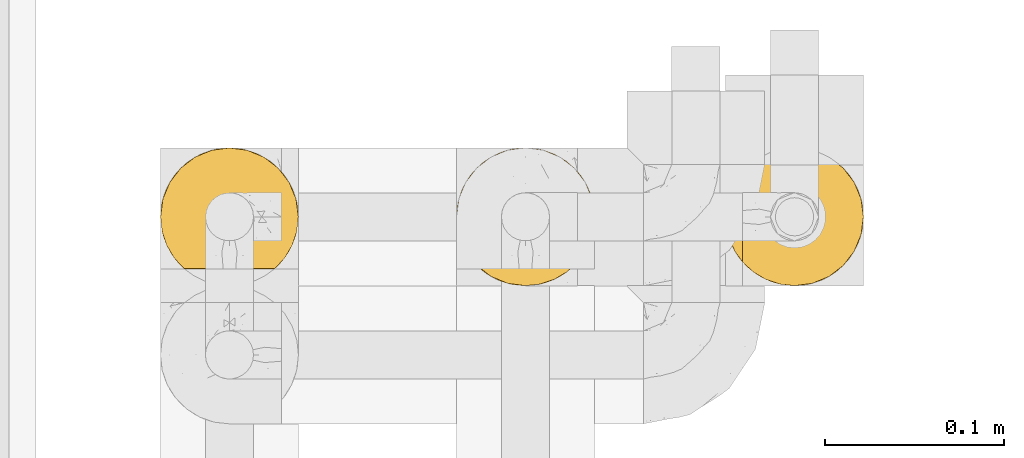
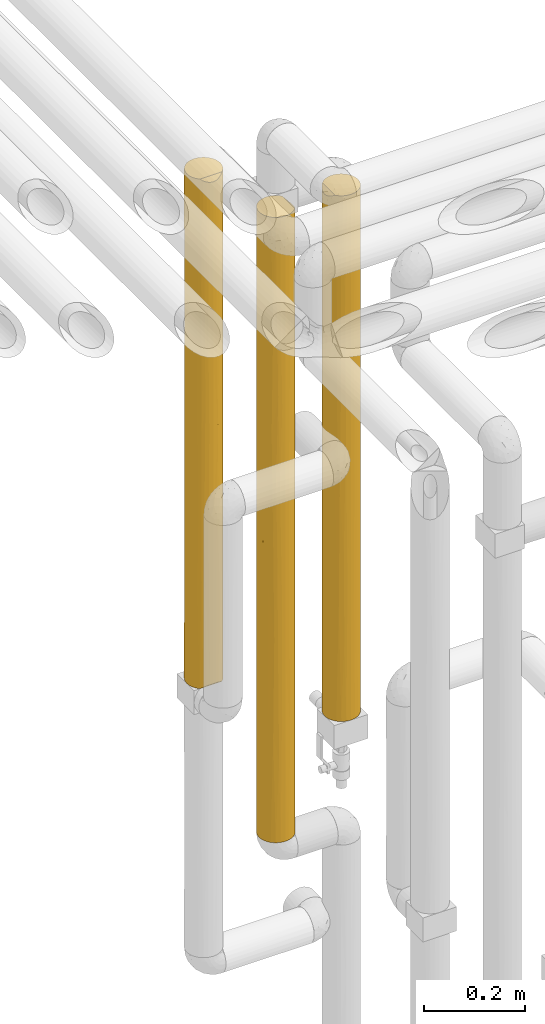
# One storey, part 40 of 827: 3 coverings.
"""IFC2X3 building model written with IfcOpenShell, lengths in millimetres."""

from ifc_helpers import new_model, entity, si_unit, converted_unit, derived_unit, direction, frame, origin, place, context, subcontext, project, spatial, faceted_brep, element, save


model = new_model("IFC2X3")

# Units and contexts
model_context = context("Model", 3, precision=0.01, world=origin(), true_north=direction((6.12303176911189e-17, 1.0)))
body_context = subcontext(model_context, "Body", "Model", "MODEL_VIEW")
ifc_project = project(units=[si_unit("LENGTHUNIT", "METRE", prefix="MILLI"), si_unit("AREAUNIT", "SQUARE_METRE"), si_unit("VOLUMEUNIT", "CUBIC_METRE"), converted_unit("PLANEANGLEUNIT", "DEGREE", entity("IfcRatioMeasure", 0.0174532925199433), si_unit("PLANEANGLEUNIT", "RADIAN"), dimensions=[0, 0, 0, 0, 0, 0, 0]), si_unit("MASSUNIT", "GRAM", prefix="KILO"), derived_unit("MASSDENSITYUNIT", [(si_unit("MASSUNIT", "GRAM", prefix="KILO"), 1), (si_unit("LENGTHUNIT", "METRE"), -3)]), derived_unit("MOMENTOFINERTIAUNIT", [(si_unit("LENGTHUNIT", "METRE"), 4)]), si_unit("TIMEUNIT", "SECOND"), si_unit("FREQUENCYUNIT", "HERTZ"), si_unit("THERMODYNAMICTEMPERATUREUNIT", "DEGREE_CELSIUS"), derived_unit("THERMALTRANSMITTANCEUNIT", [(si_unit("MASSUNIT", "GRAM", prefix="KILO"), 1), (si_unit("THERMODYNAMICTEMPERATUREUNIT", "KELVIN"), -1), (si_unit("TIMEUNIT", "SECOND"), -3)]), derived_unit("VOLUMETRICFLOWRATEUNIT", [(si_unit("LENGTHUNIT", "METRE"), 3), (si_unit("TIMEUNIT", "SECOND"), -1)]), derived_unit("MASSFLOWRATEUNIT", [(si_unit("MASSUNIT", "GRAM", prefix="KILO"), 1), (si_unit("TIMEUNIT", "SECOND"), -1)]), derived_unit("ROTATIONALFREQUENCYUNIT", [(si_unit("TIMEUNIT", "SECOND"), -1)]), si_unit("ELECTRICCURRENTUNIT", "AMPERE"), si_unit("ELECTRICVOLTAGEUNIT", "VOLT"), si_unit("POWERUNIT", "WATT"), si_unit("FORCEUNIT", "NEWTON", prefix="KILO"), si_unit("ILLUMINANCEUNIT", "LUX"), si_unit("LUMINOUSFLUXUNIT", "LUMEN"), si_unit("LUMINOUSINTENSITYUNIT", "CANDELA"), derived_unit("USERDEFINED", [(si_unit("MASSUNIT", "GRAM", prefix="KILO"), -1), (si_unit("LENGTHUNIT", "METRE"), -2), (si_unit("TIMEUNIT", "SECOND"), 3), (si_unit("LUMINOUSFLUXUNIT", "LUMEN"), 1)]), derived_unit("LINEARVELOCITYUNIT", [(si_unit("LENGTHUNIT", "METRE"), 1), (si_unit("TIMEUNIT", "SECOND"), -1)]), si_unit("PRESSUREUNIT", "PASCAL"), derived_unit("USERDEFINED", [(si_unit("LENGTHUNIT", "METRE"), -2), (si_unit("MASSUNIT", "GRAM", prefix="KILO"), 1), (si_unit("TIMEUNIT", "SECOND"), -2)]), derived_unit("LINEARFORCEUNIT", [(si_unit("MASSUNIT", "GRAM", prefix="KILO"), 1), (si_unit("LENGTHUNIT", "METRE"), 1), (si_unit("TIMEUNIT", "SECOND"), -2), (si_unit("LENGTHUNIT", "METRE"), -1)]), derived_unit("PLANARFORCEUNIT", [(si_unit("MASSUNIT", "GRAM", prefix="KILO"), 1), (si_unit("LENGTHUNIT", "METRE"), 1), (si_unit("TIMEUNIT", "SECOND"), -2), (si_unit("LENGTHUNIT", "METRE"), -2)])], contexts=[model_context])

# Site, building, storey
site_placement = place(None, origin())
site = spatial("IfcSite", under=ifc_project, at=site_placement, CompositionType="ELEMENT")
building_placement = place(site_placement, origin())
building = spatial("IfcBuilding", under=site, at=building_placement, CompositionType="ELEMENT")
storey_placement = place(building_placement, frame((0.0, 0.0, 28200.0)))
storey = spatial("IfcBuildingStorey", under=building, at=storey_placement, Name="08", CompositionType="ELEMENT", Elevation=28200.0)

# Coverings
covering_1_placement = place(storey_placement, frame((34787.85, 15782.05, 1737.4)))
element("IfcCovering", 1, at=covering_1_placement, inside=storey, Name=":ADSK_", ObjectType=":ADSK_", PredefinedType="INSULATION", context=body_context, shape_type="Brep", body=[
    faceted_brep([(70.82, 17.09, 1233.7), (74.96, 24.12, 1233.7), (77.53, 31.87, 1233.7), (78.4, 40.0, 1233.7), (77.09, 49.93, 1233.7), (73.25, 59.2, 1233.7), (67.15, 67.15, 1233.7), (59.2, 73.25, 1233.7), (49.93, 77.09, 1233.7), (40.0, 78.4, 1233.7), (30.06, 77.09, 1233.7), (20.8, 73.25, 1233.7), (12.84, 67.15, 1233.7), (6.74, 59.2, 1233.7), (2.9, 49.93, 1233.7), (1.6, 40.0, 1233.7), (2.47, 31.87, 1233.7), (5.03, 24.12, 1233.7), (9.17, 17.09, 1233.7), (14.71, 11.1, 1233.7), (65.28, 11.1, 1233.7), (77.09, 49.93, 1.6), (78.4, 40.0, 1.6), (77.52, 31.83, 1.6), (74.93, 24.05, 1.6), (70.75, 17.0, 1.6), (65.17, 11.0, 1.6), (14.82, 11.0, 1.6), (9.24, 17.0, 1.6), (5.06, 24.05, 1.6), (2.47, 31.83, 1.6), (1.6, 40.0, 1.6), (2.9, 49.93, 1.6), (6.74, 59.2, 1.6), (12.84, 67.15, 1.6), (20.8, 73.25, 1.6), (30.06, 77.09, 1.6), (40.0, 78.4, 1.6), (49.93, 77.09, 1.6), (59.2, 73.25, 1.6), (67.15, 67.15, 1.6), (73.25, 59.2, 1.6), (6.96, 20.41, 380.1), (2.98, 29.79, 300.66), (33.13, 2.21, 1224.81), (26.49, 4.05, 1226.65), (29.66, 3.01, 854.96), (1.6, 40.0, 1017.32), (3.54, 27.93, 959.65), (29.71, 3.0, 379.5), (40.0, 1.6, 314.3), (31.58, 2.53, 617.43), (6.92, 20.49, 1020.27), (6.91, 20.5, 776.67), (2.89, 30.11, 632.09), (17.23, 9.07, 932.57), (11.14, 14.65, 898.16), (11.15, 14.65, 658.7), (1.6, 40.0, 368.2), (1.6, 40.0, 217.97), (20.38, 6.98, 5.61), (26.56, 4.02, 8.57), (23.95, 5.11, 227.33), (7.37, 19.74, 578.55), (17.34, 8.99, 302.5), (11.15, 14.64, 236.7), (22.57, 5.78, 457.71), (33.17, 2.21, 10.38), (40.0, 1.6, 920.9), (24.03, 5.07, 687.57), (20.28, 7.04, 1229.64), (23.14, 5.49, 889.56), (17.16, 9.12, 617.33), (40.0, 1.6, 1007.82), (40.0, 1.6, 1224.2), (40.0, 1.6, 443.74), (40.0, 1.6, 617.6), (40.0, 1.6, 791.45), (1.6, 40.0, 800.95), (1.6, 40.0, 650.72), (1.6, 40.0, 584.58), (1.6, 40.0, 434.34), (12.88, 12.81, 447.73), (40.0, 1.6, 11.0), (40.0, 1.6, 227.37), (1.6, 40.0, 867.09), (46.86, 2.21, 1224.81), (78.4, 40.0, 368.2), (77.01, 29.79, 300.8), (62.94, 9.2, 617.95), (56.74, 5.44, 340.29), (65.84, 11.59, 318.76), (62.5, 8.88, 1022.28), (64.23, 10.21, 822.23), (68.21, 13.95, 960.82), (56.83, 5.48, 896.27), (59.71, 7.04, 1229.64), (53.5, 4.05, 1226.65), (59.61, 6.98, 5.61), (78.4, 40.0, 1017.32), (73.03, 20.41, 381.62), (46.82, 2.21, 10.38), (53.43, 4.02, 8.57), (48.19, 2.48, 335.55), (48.24, 2.49, 899.64), (73.08, 20.5, 1021.95), (76.45, 27.93, 960.83), (77.09, 30.08, 632.84), (73.08, 20.5, 779.63), (52.39, 3.65, 617.28), (74.53, 23.2, 580.01), (69.54, 15.47, 581.84), (78.4, 40.0, 800.95), (78.4, 40.0, 584.58), (70.46, 63.37, 260.79), (63.37, 70.46, 325.87), (77.74, 47.07, 909.14), (77.52, 48.15, 600.24), (75.47, 54.69, 874.58), (75.47, 54.69, 360.71), (77.67, 47.41, 240.44), (40.0, 78.4, 217.97), (74.83, 56.16, 600.23), (47.38, 77.68, 930.39), (54.69, 75.47, 246.65), (62.73, 70.94, 600.23), (54.69, 75.47, 531.31), (47.28, 77.7, 326.15), (63.37, 70.46, 874.58), (54.69, 75.47, 966.5), (70.46, 63.37, 966.5), (51.75, 76.55, 748.91), (70.46, 63.37, 617.65), (46.88, 77.77, 563.24), (40.0, 78.4, 368.2), (40.0, 78.4, 434.34), (40.0, 78.4, 650.71), (40.0, 78.4, 800.95), (40.0, 78.4, 867.08), (40.0, 78.4, 1017.32), (40.0, 78.4, 584.57), (16.62, 70.46, 260.79), (9.53, 63.37, 325.87), (32.92, 77.74, 909.14), (31.84, 77.52, 600.24), (25.3, 75.47, 874.58), (25.3, 75.47, 360.71), (32.58, 77.67, 240.44), (23.83, 74.83, 600.23), (2.31, 47.38, 930.39), (4.52, 54.69, 246.65), (9.05, 62.73, 600.23), (4.52, 54.69, 531.31), (2.29, 47.28, 326.15), (9.53, 63.37, 874.58), (4.52, 54.69, 966.5), (16.62, 70.46, 966.5), (3.44, 51.75, 748.91), (16.62, 70.46, 617.65), (2.22, 46.88, 563.24)], [[[0, 1, 2, 3, 4, 5, 6, 7, 8, 9, 10, 11, 12, 13, 14, 15, 16, 17, 18, 19, 20]], [[21, 22, 23, 24, 25, 26, 27, 28, 29, 30, 31, 32, 33, 34, 35, 36, 37, 38, 39, 40, 41]], [[42, 43, 29]], [[44, 45, 46]], [[16, 47, 48]], [[48, 17, 16]], [[49, 50, 51]], [[52, 48, 53]], [[53, 48, 54]], [[30, 43, 31]], [[55, 56, 57]], [[43, 58, 59, 31]], [[60, 61, 62]], [[63, 54, 42]], [[48, 52, 17]], [[27, 64, 65]], [[28, 65, 42]], [[62, 49, 66]], [[67, 62, 61]], [[29, 28, 42]], [[44, 46, 68]], [[56, 18, 52]], [[66, 51, 69]], [[67, 50, 49]], [[62, 67, 49]], [[45, 70, 71]], [[72, 55, 57]], [[44, 68, 73, 74]], [[19, 18, 56]], [[70, 19, 55]], [[51, 50, 75, 76, 77, 68]], [[71, 70, 55]], [[72, 69, 71]], [[60, 64, 27]], [[54, 78, 79, 80, 81, 58]], [[72, 57, 82]], [[54, 48, 78]], [[58, 43, 54]], [[56, 52, 53]], [[17, 52, 18]], [[56, 53, 57]], [[56, 55, 19]], [[53, 63, 57]], [[42, 65, 82]], [[54, 63, 53]], [[82, 63, 42]], [[51, 68, 46]], [[67, 83, 84, 50]], [[69, 51, 46]], [[71, 69, 46]], [[72, 64, 66]], [[45, 71, 46]], [[72, 71, 55]], [[29, 43, 30]], [[54, 43, 42]], [[49, 51, 66]], [[60, 62, 64]], [[72, 66, 69]], [[64, 62, 66]], [[27, 65, 28]], [[82, 65, 64]], [[72, 82, 64]], [[82, 57, 63]], [[47, 16, 15]], [[48, 47, 85, 78]], [[86, 74, 73]], [[87, 88, 22]], [[89, 90, 91]], [[92, 93, 94]], [[95, 96, 97]], [[98, 91, 90]], [[91, 98, 26]], [[99, 3, 2]], [[91, 25, 100]], [[101, 102, 103]], [[20, 94, 0]], [[102, 98, 90]], [[104, 73, 68, 77]], [[1, 105, 106]], [[73, 104, 86]], [[107, 106, 108]], [[103, 109, 75]], [[20, 96, 92]], [[88, 23, 22]], [[24, 23, 88]], [[100, 110, 111]], [[0, 105, 1]], [[1, 106, 2]], [[92, 96, 95]], [[106, 107, 112]], [[88, 107, 110]], [[97, 86, 104]], [[84, 83, 101]], [[2, 106, 99]], [[89, 95, 109]], [[103, 90, 109]], [[108, 105, 94]], [[94, 93, 111]], [[25, 24, 100]], [[103, 102, 90]], [[103, 75, 50, 84]], [[101, 103, 84]], [[95, 104, 109]], [[109, 77, 76, 75]], [[104, 95, 97]], [[109, 90, 89]], [[77, 109, 104]], [[110, 107, 108]], [[107, 87, 113, 112]], [[94, 105, 0]], [[106, 105, 108]], [[25, 91, 26]], [[111, 91, 100]], [[24, 88, 100]], [[94, 111, 108]], [[91, 111, 89]], [[93, 95, 89]], [[20, 92, 94]], [[95, 93, 92]], [[111, 93, 89]], [[106, 112, 99]], [[111, 110, 108]], [[88, 110, 100]], [[87, 107, 88]], [[114, 40, 115]], [[116, 117, 118]], [[4, 99, 116]], [[4, 118, 5]], [[21, 41, 119]], [[120, 22, 21]], [[38, 37, 121]], [[87, 120, 117]], [[118, 117, 122]], [[9, 8, 123]], [[39, 124, 115]], [[125, 115, 126]], [[124, 127, 126]], [[120, 21, 119]], [[112, 116, 99]], [[128, 129, 7]], [[130, 6, 5]], [[39, 38, 124]], [[39, 115, 40]], [[118, 130, 5]], [[128, 7, 6]], [[123, 129, 131]], [[128, 130, 132]], [[132, 114, 115]], [[125, 132, 115]], [[7, 129, 8]], [[40, 114, 41]], [[126, 127, 133]], [[114, 132, 119]], [[132, 130, 118]], [[131, 128, 125]], [[131, 126, 133]], [[128, 6, 130]], [[119, 41, 114]], [[121, 127, 38]], [[115, 124, 126]], [[127, 121, 134, 135]], [[127, 135, 133]], [[38, 127, 124]], [[123, 136, 137, 138, 139, 9]], [[133, 136, 131]], [[4, 3, 99]], [[128, 131, 129]], [[8, 129, 123]], [[136, 123, 131]], [[133, 135, 140, 136]], [[117, 116, 112]], [[4, 116, 118]], [[117, 112, 113, 87]], [[117, 119, 122]], [[117, 120, 119]], [[22, 120, 87]], [[131, 125, 126]], [[132, 125, 128]], [[119, 132, 122]], [[118, 122, 132]], [[141, 34, 142]], [[143, 144, 145]], [[10, 139, 143]], [[10, 145, 11]], [[36, 35, 146]], [[147, 37, 36]], [[32, 31, 59]], [[134, 147, 144]], [[145, 144, 148]], [[15, 14, 149]], [[33, 150, 142]], [[151, 142, 152]], [[150, 153, 152]], [[147, 36, 146]], [[143, 139, 138, 137]], [[154, 155, 13]], [[156, 12, 11]], [[33, 32, 150]], [[33, 142, 34]], [[145, 156, 11]], [[154, 13, 12]], [[149, 155, 157]], [[154, 156, 158]], [[158, 141, 142]], [[151, 158, 142]], [[13, 155, 14]], [[34, 141, 35]], [[152, 153, 159]], [[141, 158, 146]], [[157, 154, 151]], [[157, 152, 159]], [[158, 156, 145]], [[154, 12, 156]], [[146, 35, 141]], [[59, 153, 32]], [[142, 150, 152]], [[153, 59, 58, 81]], [[153, 81, 159]], [[32, 153, 150]], [[149, 79, 78, 85, 47, 15]], [[159, 79, 157]], [[10, 9, 139]], [[154, 157, 155]], [[14, 155, 149]], [[79, 149, 157]], [[159, 81, 80, 79]], [[144, 143, 137]], [[10, 143, 145]], [[144, 137, 136, 140, 135, 134]], [[144, 146, 148]], [[144, 147, 146]], [[147, 134, 121, 37]], [[157, 151, 152]], [[158, 151, 154]], [[146, 158, 148]], [[145, 148, 158]], [[70, 45, 44, 74, 86, 97, 96, 20, 19]], [[98, 102, 101, 83, 67, 61, 60, 27, 26]]]),
])
covering_2_placement = place(storey_placement, frame((34952.89, 15782.05, 1307.5)))
element("IfcCovering", 2, at=covering_2_placement, inside=storey, Name=":ADSK_", ObjectType=":ADSK_", PredefinedType="INSULATION", context=body_context, shape_type="Brep", body=[
    faceted_brep([(6.74, 20.8, 1.6), (2.9, 30.06, 1.6), (1.6, 40.0, 1.6), (2.9, 49.93, 1.6), (6.74, 59.2, 1.6), (12.84, 67.15, 1.6), (20.8, 73.25, 1.6), (30.06, 77.09, 1.6), (40.0, 78.4, 1.6), (48.2, 77.51, 1.6), (56.01, 74.9, 1.6), (63.08, 70.68, 1.6), (69.1, 65.05, 1.6), (69.1, 14.94, 1.6), (63.08, 9.31, 1.6), (56.01, 5.09, 1.6), (48.2, 2.48, 1.6), (40.0, 1.6, 1.6), (30.06, 2.9, 1.6), (20.8, 6.74, 1.6), (12.84, 12.84, 1.6), (1.6, 40.0, 1513.5), (2.9, 30.06, 1513.5), (6.74, 20.8, 1513.5), (12.84, 12.84, 1513.5), (20.8, 6.74, 1513.5), (30.06, 2.9, 1513.5), (40.0, 1.6, 1513.5), (48.16, 2.47, 1513.5), (55.94, 5.06, 1513.5), (62.99, 9.24, 1513.5), (69.0, 14.82, 1513.5), (69.0, 65.17, 1513.5), (62.99, 70.75, 1513.5), (55.94, 74.93, 1513.5), (48.16, 77.52, 1513.5), (40.0, 78.4, 1513.5), (30.06, 77.09, 1513.5), (20.8, 73.25, 1513.5), (12.84, 67.15, 1513.5), (6.74, 59.2, 1513.5), (2.9, 49.93, 1513.5), (9.53, 63.37, 1254.3), (8.19, 61.51, 485.12), (17.02, 70.76, 616.68), (16.62, 70.46, 297.59), (16.62, 70.46, 1189.22), (2.34, 47.54, 1188.94), (4.37, 54.34, 1314.28), (4.52, 54.69, 1074.52), (25.3, 75.47, 204.96), (31.9, 77.53, 329.8), (2.32, 47.41, 921.21), (1.6, 40.0, 1080.75), (4.9, 55.59, 800.5), (1.6, 40.0, 324.8), (2.43, 47.94, 288.89), (40.0, 78.4, 324.8), (31.64, 77.48, 539.4), (33.12, 77.77, 951.85), (28.03, 76.48, 719.21), (25.3, 75.47, 983.78), (25.3, 75.47, 1268.44), (32.71, 77.7, 1188.94), (9.53, 63.37, 255.92), (4.52, 54.69, 175.66), (2.55, 48.52, 674.17), (25.3, 75.47, 454.64), (4.52, 54.69, 402.11), (17.9, 71.4, 946.7), (11.57, 65.81, 984.31), (40.0, 78.4, 1297.12), (1.6, 40.0, 1297.12), (1.6, 40.0, 648.0), (1.6, 40.0, 864.38), (9.53, 63.37, 714.31), (40.0, 78.4, 1080.75), (40.0, 78.4, 864.38), (40.0, 78.4, 648.0), (4.52, 54.69, 602.29), (40.0, 78.4, 217.97), (40.0, 78.4, 434.34), (48.41, 77.46, 864.38), (55.63, 75.07, 815.72), (49.96, 77.08, 541.17), (52.17, 76.41, 262.4), (59.58, 73.03, 1000.69), (52.12, 76.43, 1216.13), (59.58, 73.03, 1294.15), (59.71, 72.95, 245.23), (77.78, 46.82, 1504.71), (78.4, 40.0, 1287.72), (77.0, 50.24, 1261.84), (78.4, 40.0, 443.64), (78.4, 40.0, 227.27), (77.5, 48.24, 335.45), (76.0, 53.36, 8.5), (74.58, 56.68, 384.99), (74.53, 56.78, 1092.98), (73.77, 58.26, 1300.86), (75.97, 53.43, 1506.52), (66.14, 68.12, 1216.12), (67.04, 67.25, 938.77), (77.79, 46.78, 10.29), (70.57, 63.23, 410.64), (71.13, 62.48, 196.11), (66.24, 68.03, 287.24), (66.5, 67.78, 548.36), (78.4, 40.0, 1071.35), (77.38, 48.77, 973.87), (59.66, 72.98, 485.18), (78.4, 40.0, 876.39), (76.88, 50.68, 653.07), (78.4, 40.0, 660.02), (70.87, 62.83, 1155.43), (71.79, 61.52, 947.04), (73.07, 59.51, 5.57), (62.05, 71.43, 743.38), (75.0, 55.77, 846.38), (78.4, 40.0, 10.9), (73.01, 59.61, 1509.48), (74.34, 57.17, 650.34), (70.91, 62.77, 717.19), (78.4, 40.0, 1504.1), (52.17, 3.58, 262.4), (59.66, 7.01, 485.18), (49.96, 2.91, 541.17), (73.77, 21.73, 1300.86), (77.0, 29.75, 1261.84), (75.97, 26.56, 1506.52), (71.13, 17.51, 196.11), (74.58, 23.31, 384.99), (70.57, 16.76, 410.64), (40.0, 1.6, 434.34), (70.91, 17.22, 717.19), (62.05, 8.56, 743.38), (66.5, 12.21, 548.36), (52.12, 3.56, 1216.13), (59.58, 6.96, 1238.43), (70.87, 17.16, 1155.43), (66.14, 11.87, 1216.12), (77.78, 33.17, 1504.71), (67.04, 12.74, 938.77), (71.79, 18.47, 947.04), (76.0, 26.63, 8.5), (77.5, 31.75, 335.45), (77.79, 33.21, 10.29), (77.38, 31.23, 973.87), (55.63, 4.92, 815.72), (73.01, 20.38, 1509.48), (40.0, 1.6, 1297.12), (40.0, 1.6, 1190.29), (40.0, 1.6, 1080.75), (76.88, 29.31, 653.07), (59.58, 6.96, 1000.69), (59.75, 7.07, 217.41), (66.24, 11.96, 287.24), (48.41, 2.53, 864.38), (40.0, 1.6, 648.0), (40.0, 1.6, 867.09), (40.0, 1.6, 864.38), (40.0, 1.6, 650.71), (40.0, 1.6, 217.97), (75.0, 24.22, 846.38), (74.34, 22.82, 650.34), (74.53, 23.21, 1092.98), (73.07, 20.48, 5.57), (16.62, 9.53, 1254.3), (9.53, 16.62, 1189.22), (25.3, 4.52, 406.92), (32.71, 2.29, 326.15), (32.07, 2.42, 623.25), (25.3, 4.52, 1079.45), (22.93, 5.59, 1282.78), (28.78, 3.27, 853.31), (33.21, 2.2, 1053.48), (21.48, 6.35, 883.7), (23.82, 5.17, 655.64), (2.46, 31.9, 329.8), (2.52, 31.64, 539.4), (16.62, 9.53, 255.92), (9.53, 16.62, 297.59), (8.59, 17.9, 946.93), (14.15, 11.59, 989.78), (4.52, 25.3, 1268.44), (2.29, 32.71, 1188.94), (4.52, 25.3, 983.78), (18.36, 8.27, 490.59), (9.25, 16.99, 618.61), (2.22, 33.12, 951.85), (3.51, 28.03, 719.21), (4.52, 25.3, 204.96), (26.92, 3.89, 196.25), (4.52, 25.3, 454.64), (29.95, 2.93, 1273.39), (16.62, 9.53, 725.25)], [[[0, 1, 2, 3, 4, 5, 6, 7, 8, 9, 10, 11, 12, 13, 14, 15, 16, 17, 18, 19, 20]], [[21, 22, 23, 24, 25, 26, 27, 28, 29, 30, 31, 32, 33, 34, 35, 36, 37, 38, 39, 40, 41]], [[39, 42, 40]], [[43, 44, 45]], [[42, 39, 46]], [[47, 48, 49]], [[7, 50, 51]], [[52, 53, 47]], [[49, 54, 52]], [[2, 55, 56]], [[57, 51, 58]], [[59, 60, 61]], [[38, 37, 62]], [[6, 5, 45]], [[62, 63, 61]], [[62, 46, 38]], [[38, 46, 39]], [[7, 6, 50]], [[45, 5, 64]], [[4, 3, 65]], [[52, 54, 66]], [[67, 45, 44]], [[45, 67, 50]], [[56, 68, 65]], [[46, 69, 70]], [[37, 36, 71]], [[61, 63, 59]], [[72, 41, 47]], [[70, 49, 42]], [[5, 4, 64]], [[7, 51, 8]], [[64, 43, 45]], [[70, 42, 46]], [[47, 49, 52]], [[66, 55, 73, 74]], [[48, 42, 49]], [[65, 64, 4]], [[43, 64, 68]], [[71, 63, 37]], [[46, 62, 61]], [[75, 70, 69]], [[44, 69, 60]], [[46, 61, 69]], [[70, 75, 54]], [[63, 71, 76]], [[63, 76, 59]], [[37, 63, 62]], [[60, 77, 78]], [[51, 67, 58]], [[59, 77, 60]], [[44, 60, 67]], [[59, 76, 77]], [[47, 53, 72]], [[72, 21, 41]], [[48, 47, 41]], [[70, 54, 49]], [[66, 74, 52]], [[79, 75, 43]], [[75, 79, 54]], [[41, 40, 48]], [[42, 48, 40]], [[54, 79, 66]], [[66, 68, 56]], [[45, 50, 6]], [[51, 50, 67]], [[67, 60, 58]], [[51, 57, 80, 8]], [[60, 78, 58]], [[58, 78, 81, 57]], [[60, 69, 61]], [[75, 69, 44]], [[74, 53, 52]], [[68, 66, 79]], [[3, 2, 56]], [[64, 65, 68]], [[3, 56, 65]], [[66, 56, 55]], [[79, 43, 68]], [[44, 43, 75]], [[82, 83, 84]], [[9, 80, 85]], [[86, 87, 88]], [[88, 34, 33]], [[82, 84, 78]], [[85, 89, 10]], [[90, 91, 92]], [[93, 94, 95]], [[87, 35, 34]], [[95, 96, 97]], [[98, 99, 92]], [[100, 90, 92]], [[33, 32, 101]], [[87, 71, 35]], [[82, 78, 77, 76]], [[84, 85, 81]], [[86, 101, 102]], [[88, 33, 101]], [[103, 96, 95]], [[104, 105, 106]], [[107, 104, 106]], [[92, 108, 109]], [[84, 81, 78]], [[89, 85, 110]], [[111, 109, 108]], [[106, 12, 11]], [[112, 111, 113, 93]], [[114, 98, 115]], [[96, 116, 105]], [[102, 117, 86]], [[109, 118, 98]], [[100, 92, 99]], [[94, 119, 103]], [[9, 85, 10]], [[89, 110, 106]], [[95, 112, 93]], [[109, 112, 118]], [[32, 120, 99]], [[98, 118, 115]], [[82, 87, 86]], [[35, 71, 36]], [[111, 112, 109]], [[109, 98, 92]], [[107, 110, 117]], [[105, 116, 12]], [[103, 95, 94]], [[112, 95, 97]], [[118, 121, 122]], [[80, 9, 8]], [[106, 11, 89]], [[110, 85, 84]], [[87, 82, 76]], [[83, 86, 117]], [[121, 118, 112]], [[76, 71, 87]], [[115, 122, 102]], [[114, 115, 102]], [[122, 107, 117]], [[122, 117, 102]], [[110, 84, 83]], [[122, 121, 104]], [[106, 110, 107]], [[122, 115, 118]], [[114, 102, 101]], [[32, 114, 101]], [[99, 98, 114]], [[32, 99, 114]], [[99, 120, 100]], [[122, 104, 107]], [[97, 96, 105]], [[106, 105, 12]], [[97, 105, 104]], [[83, 117, 110]], [[82, 86, 83]], [[112, 97, 121]], [[104, 121, 97]], [[86, 88, 101]], [[34, 88, 87]], [[91, 90, 123]], [[91, 108, 92]], [[85, 80, 57, 81]], [[10, 89, 11]], [[124, 125, 126]], [[127, 128, 129]], [[130, 131, 132]], [[124, 126, 133]], [[134, 135, 136]], [[137, 138, 29]], [[139, 31, 140]], [[141, 129, 128]], [[142, 143, 139]], [[130, 144, 131]], [[94, 145, 146]], [[140, 31, 30]], [[111, 108, 147]], [[128, 91, 141]], [[145, 94, 93]], [[126, 125, 148]], [[149, 127, 129]], [[137, 150, 151, 152]], [[131, 145, 153]], [[111, 147, 153]], [[140, 138, 154]], [[16, 15, 124]], [[125, 124, 155]], [[138, 137, 154]], [[14, 13, 156]], [[157, 158, 126]], [[157, 152, 159, 160, 161, 158]], [[135, 134, 142]], [[155, 14, 156]], [[16, 124, 162]], [[144, 146, 145]], [[141, 91, 123]], [[158, 133, 126]], [[29, 28, 137]], [[153, 147, 163]], [[163, 164, 153]], [[142, 140, 154]], [[142, 139, 140]], [[137, 28, 150]], [[157, 137, 152]], [[165, 147, 128]], [[108, 128, 147]], [[130, 13, 166]], [[132, 134, 136]], [[146, 119, 94]], [[14, 155, 15]], [[17, 16, 162]], [[153, 145, 93]], [[145, 131, 144]], [[113, 111, 153, 93]], [[147, 165, 163]], [[148, 125, 135]], [[137, 157, 154]], [[28, 27, 150]], [[143, 163, 165]], [[164, 163, 134]], [[135, 142, 154]], [[134, 163, 143]], [[148, 135, 154]], [[135, 125, 136]], [[125, 156, 136]], [[132, 136, 156]], [[143, 165, 139]], [[134, 143, 142]], [[165, 127, 139]], [[139, 127, 31]], [[128, 127, 165]], [[31, 127, 149]], [[156, 13, 130]], [[132, 131, 164]], [[130, 166, 144]], [[156, 130, 132]], [[154, 157, 148]], [[126, 148, 157]], [[132, 164, 134]], [[131, 153, 164]], [[140, 30, 138]], [[29, 138, 30]], [[128, 108, 91]], [[125, 155, 156]], [[15, 155, 124]], [[124, 133, 162]], [[167, 24, 168]], [[169, 170, 171]], [[18, 162, 170]], [[25, 24, 167]], [[167, 172, 173]], [[174, 175, 172]], [[22, 21, 72]], [[174, 176, 177]], [[171, 177, 169]], [[55, 178, 179]], [[180, 181, 20]], [[168, 182, 183]], [[184, 185, 186]], [[181, 187, 188]], [[189, 190, 186]], [[1, 0, 191]], [[192, 18, 170]], [[23, 22, 184]], [[23, 168, 24]], [[193, 181, 188]], [[181, 193, 191]], [[168, 184, 186]], [[1, 191, 178]], [[0, 20, 181]], [[133, 170, 162]], [[194, 172, 175]], [[184, 168, 23]], [[186, 185, 189]], [[183, 172, 167]], [[20, 19, 180]], [[1, 178, 2]], [[180, 187, 181]], [[183, 167, 168]], [[26, 194, 27]], [[173, 172, 194]], [[192, 180, 19]], [[187, 180, 169]], [[72, 185, 22]], [[195, 183, 182]], [[188, 182, 190]], [[168, 186, 182]], [[183, 195, 176]], [[185, 72, 53]], [[185, 53, 189]], [[22, 185, 184]], [[190, 74, 73]], [[178, 193, 179]], [[189, 74, 190]], [[188, 190, 193]], [[189, 53, 74]], [[18, 17, 162]], [[171, 170, 133]], [[170, 169, 192]], [[171, 133, 158, 161, 160, 159]], [[174, 172, 176]], [[180, 192, 169]], [[19, 18, 192]], [[190, 182, 186]], [[195, 182, 188]], [[181, 191, 0]], [[178, 191, 193]], [[193, 190, 179]], [[178, 55, 2]], [[190, 73, 179]], [[55, 179, 73]], [[177, 171, 174]], [[187, 177, 195]], [[171, 159, 174]], [[175, 159, 152, 151]], [[159, 175, 174]], [[194, 151, 150, 27]], [[151, 194, 175]], [[173, 26, 25]], [[183, 176, 172]], [[177, 176, 195]], [[26, 173, 194]], [[25, 167, 173]], [[177, 187, 169]], [[188, 187, 195]], [[12, 116, 96, 103, 119, 146, 144, 166, 13]], [[31, 149, 129, 141, 123, 90, 100, 120, 32]]]),
])
covering_3_placement = place(storey_placement, frame((35102.89, 15782.05, 1549.85)))
element("IfcCovering", 3, at=covering_3_placement, inside=storey, Name=":ADSK_", ObjectType=":ADSK_", PredefinedType="INSULATION", context=body_context, shape_type="Brep", body=[
    faceted_brep([(73.25, 20.8, 1271.05), (77.09, 30.06, 1271.05), (78.4, 40.0, 1271.05), (77.09, 49.93, 1271.05), (73.25, 59.2, 1271.05), (67.15, 67.15, 1271.05), (59.2, 73.25, 1271.05), (49.93, 77.09, 1271.05), (40.0, 78.4, 1271.05), (31.79, 77.51, 1271.05), (23.98, 74.9, 1271.05), (16.91, 70.68, 1271.05), (10.9, 65.05, 1271.05), (10.9, 14.94, 1271.05), (16.91, 9.31, 1271.05), (23.98, 5.09, 1271.05), (31.79, 2.48, 1271.05), (40.0, 1.6, 1271.05), (49.93, 2.9, 1271.05), (59.2, 6.74, 1271.05), (67.15, 12.84, 1271.05), (73.25, 20.8, 0.0), (67.15, 12.84, 0.0), (59.2, 6.74, 0.0), (49.93, 2.9, 0.0), (40.0, 1.6, 0.0), (30.06, 2.9, 0.0), (20.8, 6.74, 0.0), (12.84, 12.84, 0.0), (6.74, 20.8, 0.0), (2.9, 30.06, 0.0), (1.6, 40.0, 0.0), (2.9, 49.93, 0.0), (6.74, 59.2, 0.0), (12.84, 67.15, 0.0), (20.8, 73.25, 0.0), (30.06, 77.09, 0.0), (40.0, 78.4, 0.0), (49.93, 77.09, 0.0), (59.2, 73.25, 0.0), (67.15, 67.15, 0.0), (73.25, 59.2, 0.0), (77.09, 49.93, 0.0), (78.4, 40.0, 0.0), (77.09, 30.06, 0.0), (70.46, 63.37, 259.19), (70.46, 63.37, 635.53), (63.37, 70.46, 903.77), (70.46, 63.37, 1001.72), (63.37, 70.46, 324.27), (78.4, 40.0, 432.75), (77.73, 47.1, 324.56), (77.47, 48.35, 644.74), (77.7, 47.26, 960.09), (78.4, 40.0, 1054.68), (78.4, 40.0, 865.49), (54.69, 75.47, 245.05), (75.47, 54.69, 367.29), (78.4, 40.0, 1068.27), (78.4, 40.0, 216.37), (47.31, 77.69, 950.11), (40.0, 78.4, 1068.27), (47.28, 77.7, 324.56), (54.69, 75.47, 529.72), (54.69, 75.47, 1001.72), (75.47, 54.69, 903.77), (46.88, 77.77, 561.65), (51.83, 76.52, 765.72), (63.03, 70.72, 614.02), (74.8, 56.22, 605.69), (40.0, 78.4, 216.37), (78.4, 40.0, 649.12), (40.0, 78.4, 405.56), (40.0, 78.4, 432.75), (40.0, 78.4, 649.12), (40.0, 78.4, 838.31), (40.0, 78.4, 865.49), (40.0, 78.4, 621.93), (40.0, 78.4, 1054.68), (27.82, 76.41, 994.44), (18.19, 71.6, 547.54), (14.07, 68.32, 731.38), (20.33, 72.98, 809.75), (20.33, 72.98, 1055.19), (13.75, 68.03, 994.43), (1.6, 40.0, 216.37), (2.29, 47.27, 306.32), (2.5, 48.3, 614.38), (1.6, 40.0, 396.26), (1.6, 40.0, 612.63), (1.6, 40.0, 829.0), (25.3, 75.47, 407.79), (26.35, 75.89, 189.76), (16.62, 70.46, 281.08), (32.49, 77.65, 310.97), (29.34, 76.89, 689.95), (2.47, 48.15, 937.19), (4.0, 53.36, 1264.15), (6.92, 59.51, 1267.08), (5.4, 56.66, 923.75), (9.4, 63.2, 861.72), (9.05, 62.73, 632.57), (4.99, 55.78, 686.7), (4.52, 54.69, 355.87), (2.2, 46.78, 1262.36), (1.6, 40.0, 1045.38), (1.6, 40.0, 1261.75), (8.87, 62.48, 1076.47), (9.53, 63.37, 252.51), (16.62, 9.53, 281.08), (9.53, 16.62, 252.51), (18.19, 8.39, 547.54), (14.07, 11.67, 731.38), (9.05, 17.26, 632.57), (2.29, 32.72, 306.32), (6.92, 20.48, 1267.08), (8.7, 17.74, 1057.17), (5.4, 23.33, 923.75), (4.52, 25.3, 355.87), (2.47, 31.84, 937.19), (2.5, 31.69, 614.38), (26.35, 4.1, 189.76), (8.9, 17.46, 844.93), (4.0, 26.63, 1264.15), (32.49, 2.34, 310.97), (40.0, 1.6, 621.93), (29.34, 3.1, 689.95), (25.3, 4.52, 407.79), (40.0, 1.6, 216.37), (40.0, 1.6, 405.56), (2.2, 33.21, 1262.36), (13.75, 11.96, 994.43), (27.82, 3.58, 994.44), (40.0, 1.6, 1054.68), (20.33, 7.01, 1056.08), (20.33, 7.01, 809.75), (5.04, 24.09, 585.95), (40.0, 1.6, 838.31), (63.37, 9.53, 259.19), (70.46, 16.62, 324.27), (47.1, 2.26, 946.49), (48.35, 2.52, 626.31), (54.69, 4.52, 903.77), (54.69, 4.52, 367.29), (47.26, 2.29, 310.97), (56.26, 5.21, 604.43), (77.69, 32.68, 950.11), (75.47, 25.3, 245.05), (70.72, 16.96, 614.02), (75.47, 25.3, 529.72), (77.7, 32.71, 324.56), (70.46, 16.62, 903.77), (75.47, 25.3, 1001.72), (63.37, 9.53, 1001.72), (63.37, 9.53, 635.53), (77.77, 33.12, 561.65), (76.52, 28.16, 765.72)], [[[0, 1, 2, 3, 4, 5, 6, 7, 8, 9, 10, 11, 12, 13, 14, 15, 16, 17, 18, 19, 20]], [[21, 22, 23, 24, 25, 26, 27, 28, 29, 30, 31, 32, 33, 34, 35, 36, 37, 38, 39, 40, 41, 42, 43, 44]], [[41, 40, 45]], [[46, 47, 48]], [[46, 45, 49]], [[50, 51, 52]], [[53, 54, 55]], [[56, 49, 39]], [[57, 42, 41]], [[51, 42, 57]], [[3, 2, 58, 54]], [[59, 43, 42]], [[60, 61, 7]], [[45, 40, 49]], [[39, 38, 56]], [[39, 49, 40]], [[56, 62, 63]], [[7, 6, 64]], [[42, 51, 59]], [[47, 64, 6]], [[4, 65, 48]], [[3, 65, 4]], [[66, 67, 63]], [[4, 48, 5]], [[47, 6, 5]], [[68, 46, 49]], [[69, 65, 52]], [[38, 37, 70]], [[61, 8, 7]], [[68, 49, 63]], [[52, 55, 71, 50]], [[63, 62, 66]], [[45, 46, 57]], [[46, 48, 65]], [[47, 5, 48]], [[47, 68, 67]], [[60, 64, 67]], [[57, 41, 45]], [[70, 62, 38]], [[49, 56, 63]], [[62, 70, 72, 73]], [[62, 73, 66]], [[38, 62, 56]], [[67, 74, 75, 76]], [[76, 60, 67]], [[66, 74, 67]], [[47, 67, 64]], [[66, 73, 77, 74]], [[7, 64, 60]], [[60, 76, 78, 61]], [[59, 51, 50]], [[57, 69, 52]], [[57, 52, 51]], [[52, 53, 55]], [[53, 52, 65]], [[54, 53, 3]], [[3, 53, 65]], [[67, 68, 63]], [[46, 68, 47]], [[57, 46, 69]], [[65, 69, 46]], [[9, 78, 79]], [[80, 81, 82]], [[83, 82, 84]], [[32, 85, 86]], [[87, 88, 89, 90]], [[91, 92, 93]], [[93, 80, 91]], [[94, 91, 95]], [[87, 90, 96]], [[94, 92, 91]], [[97, 98, 99]], [[11, 84, 12]], [[83, 79, 82]], [[100, 101, 102]], [[79, 83, 10]], [[82, 79, 95]], [[103, 87, 102]], [[104, 96, 105]], [[105, 106, 104]], [[35, 34, 93]], [[86, 85, 88]], [[32, 103, 33]], [[100, 107, 84]], [[104, 97, 96]], [[107, 98, 12]], [[93, 34, 108]], [[95, 77, 94]], [[108, 101, 93]], [[36, 70, 37]], [[79, 10, 9]], [[103, 102, 101]], [[95, 91, 80]], [[96, 97, 99]], [[90, 105, 96]], [[100, 102, 99]], [[102, 96, 99]], [[87, 86, 88]], [[34, 33, 108]], [[80, 82, 95]], [[79, 75, 95]], [[94, 77, 73, 72, 70]], [[33, 103, 108]], [[101, 108, 103]], [[93, 101, 80]], [[81, 80, 101]], [[100, 81, 101]], [[84, 82, 81]], [[70, 36, 94]], [[92, 94, 36]], [[36, 35, 92]], [[93, 92, 35]], [[32, 31, 85]], [[87, 103, 86]], [[32, 86, 103]], [[84, 11, 83]], [[10, 83, 11]], [[107, 99, 98]], [[81, 100, 84]], [[84, 107, 12]], [[99, 107, 100]], [[9, 8, 61, 78]], [[79, 78, 76, 75]], [[96, 102, 87]], [[95, 75, 74, 77]], [[28, 109, 110]], [[111, 112, 113]], [[114, 88, 85]], [[30, 85, 31]], [[13, 115, 116]], [[115, 117, 116]], [[29, 118, 30]], [[117, 119, 120]], [[121, 109, 27]], [[119, 105, 90]], [[29, 28, 110]], [[116, 117, 122]], [[123, 117, 115]], [[124, 121, 26]], [[124, 125, 126]], [[127, 111, 109]], [[114, 120, 88]], [[124, 128, 129, 125]], [[105, 119, 130]], [[13, 131, 14]], [[27, 109, 28]], [[15, 132, 16]], [[133, 16, 132]], [[134, 14, 131]], [[134, 15, 14]], [[123, 130, 119]], [[134, 135, 132]], [[136, 117, 120]], [[126, 132, 135]], [[135, 111, 126]], [[133, 17, 16]], [[130, 106, 105]], [[120, 119, 90]], [[119, 117, 123]], [[120, 90, 89, 88]], [[120, 118, 136]], [[127, 126, 111]], [[110, 113, 118]], [[126, 127, 124]], [[137, 132, 126]], [[113, 110, 109]], [[118, 29, 110]], [[112, 111, 135]], [[113, 109, 111]], [[135, 131, 112]], [[122, 131, 116]], [[26, 25, 128]], [[121, 124, 127]], [[26, 128, 124]], [[109, 121, 127]], [[27, 26, 121]], [[114, 30, 118]], [[30, 114, 85]], [[120, 114, 118]], [[135, 134, 131]], [[15, 134, 132]], [[117, 136, 122]], [[13, 116, 131]], [[113, 112, 122]], [[131, 122, 112]], [[132, 137, 133]], [[118, 113, 136]], [[136, 113, 122]], [[125, 137, 126]], [[138, 22, 139]], [[140, 141, 142]], [[18, 133, 140]], [[18, 142, 19]], [[24, 23, 143]], [[144, 129, 128]], [[44, 43, 59]], [[58, 2, 1]], [[144, 141, 129]], [[142, 141, 145]], [[146, 58, 1]], [[21, 147, 139]], [[148, 139, 149]], [[147, 150, 149]], [[24, 128, 25]], [[18, 17, 133]], [[137, 140, 133]], [[151, 152, 0]], [[153, 20, 19]], [[21, 44, 147]], [[21, 139, 22]], [[142, 153, 19]], [[151, 0, 20]], [[1, 0, 152]], [[151, 153, 154]], [[154, 138, 139]], [[148, 154, 139]], [[155, 156, 149]], [[22, 138, 23]], [[149, 150, 155]], [[138, 154, 143]], [[151, 148, 156]], [[146, 152, 156]], [[154, 153, 142]], [[151, 20, 153]], [[143, 23, 138]], [[59, 150, 44]], [[139, 147, 149]], [[150, 59, 50]], [[150, 50, 155]], [[44, 150, 147]], [[156, 71, 55]], [[55, 146, 156]], [[155, 71, 156]], [[151, 156, 152]], [[155, 50, 71]], [[1, 152, 146]], [[146, 55, 54, 58]], [[141, 140, 137]], [[18, 140, 142]], [[141, 137, 125, 129]], [[141, 143, 145]], [[144, 24, 143]], [[24, 144, 128]], [[141, 144, 143]], [[156, 148, 149]], [[154, 148, 151]], [[143, 154, 145]], [[142, 145, 154]], [[104, 106, 130, 123, 115, 13, 12, 98, 97]]]),
])

save(model, "model.ifc")
